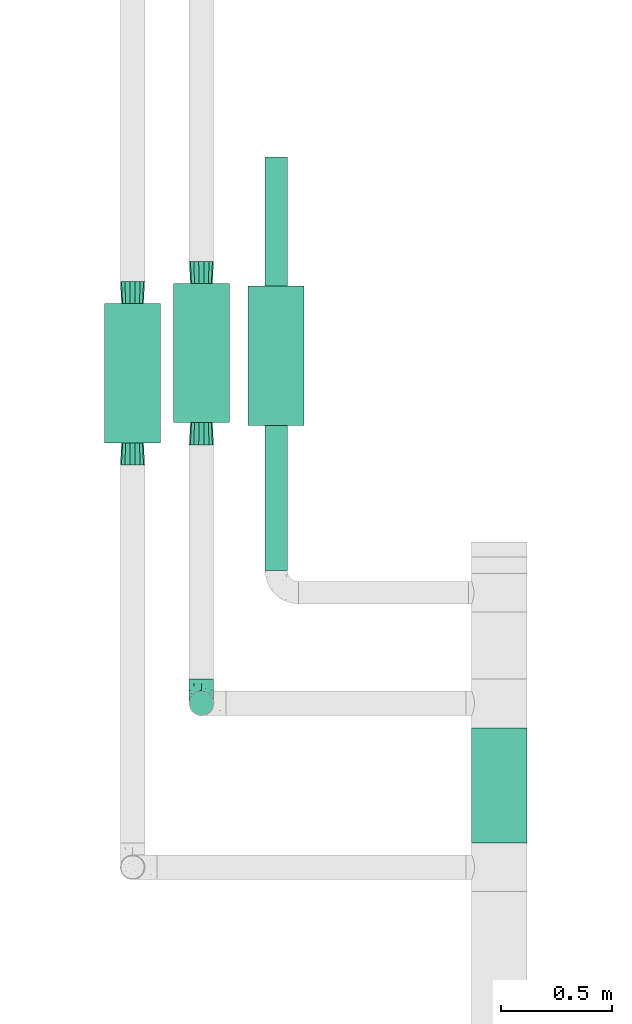
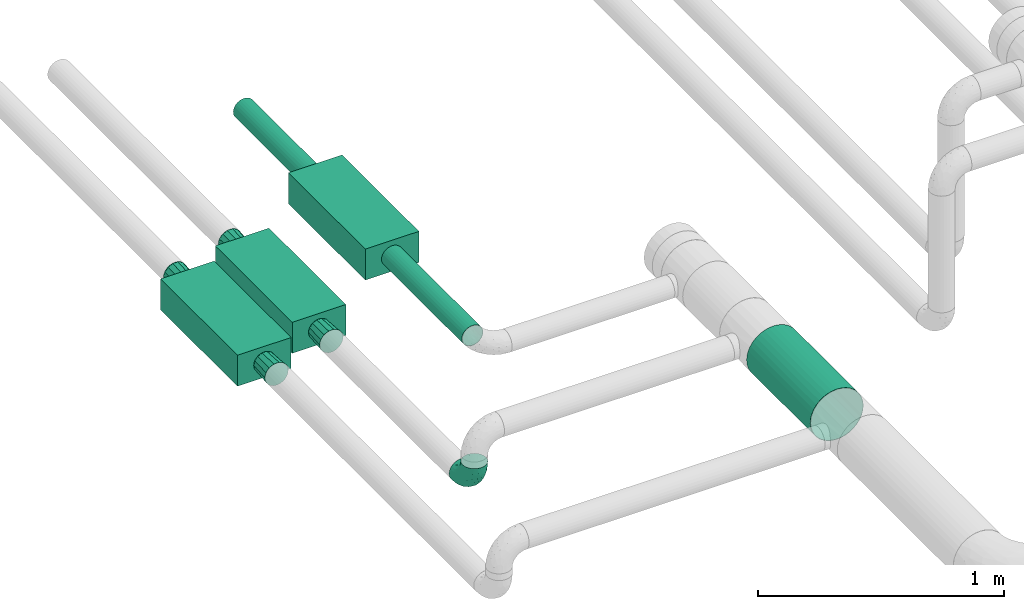
# One storey, part 38 of 91: 5 flow fittings, 3 flow segments, 3 flow treatment devices.
"""IFC2X3 building model written with IfcOpenShell, lengths in millimetres."""

from ifc_helpers import new_model, entity, si_unit, converted_unit, derived_unit, direction, frame, origin_with_axes, origin_2d_with_axis, place, context, subcontext, project, spatial, hollow_circle, extrude, open_shell, surface_model, source, transform, mapped, material, layer, layer_set, layer_usage, type_object, element, save


model = new_model("IFC2X3")

# Units and contexts
model_context = context("Model", 3, precision=1e-05, world=origin_with_axes(), true_north=direction((0.0, 1.0)))
body_context = subcontext(model_context, "Body", "Model", "MODEL_VIEW")
ifc_project = project(units=[si_unit("AREAUNIT", "SQUARE_METRE"), si_unit("VOLUMEUNIT", "CUBIC_METRE", prefix="DECI"), si_unit("TIMEUNIT", "SECOND"), si_unit("THERMODYNAMICTEMPERATUREUNIT", "DEGREE_CELSIUS"), si_unit("PRESSUREUNIT", "PASCAL"), si_unit("MASSUNIT", "GRAM", prefix="KILO"), si_unit("LENGTHUNIT", "METRE", prefix="MILLI"), si_unit("POWERUNIT", "WATT"), si_unit("ELECTRICCURRENTUNIT", "AMPERE"), si_unit("ELECTRICVOLTAGEUNIT", "VOLT"), derived_unit("VOLUMETRICFLOWRATEUNIT", [(si_unit("VOLUMEUNIT", "CUBIC_METRE", prefix="DECI"), 1), (si_unit("TIMEUNIT", "SECOND"), -1)]), derived_unit("LINEARVELOCITYUNIT", [(si_unit("LENGTHUNIT", "METRE"), 1), (si_unit("TIMEUNIT", "SECOND"), -1)]), derived_unit("MASSDENSITYUNIT", [(si_unit("MASSUNIT", "GRAM", prefix="KILO"), 1), (si_unit("VOLUMEUNIT", "CUBIC_METRE"), -1)]), converted_unit("PLANEANGLEUNIT", "DEGREE", entity("IfcRatioMeasure", 0.01745), si_unit("PLANEANGLEUNIT", "RADIAN"), dimensions=[0, 0, 0, 0, 0, 0, 0])], contexts=[model_context])

# Site, building, storey
site_placement = place(None, origin_with_axes())
site = spatial("IfcSite", under=ifc_project, at=site_placement, CompositionType="ELEMENT")
building_placement = place(site_placement, origin_with_axes())
building = spatial("IfcBuilding", under=site, at=building_placement, Name="mc-building", CompositionType="ELEMENT")
storey_placement = place(building_placement, frame((0.0, 0.0, 8700.0), z_axis=(0.0, 0.0, 1.0), x_axis=(1.0, 0.0, 0.0)))
storey = spatial("IfcBuildingStorey", under=building, at=storey_placement, CompositionType="ELEMENT", Elevation=8700.0)

# Flow segment
ifc_material = material(Name="FZ1")
ifc_layer = layer(ifc_material, 0.0)
ifc_layer_set = layer_set([ifc_layer], Name="FZ1")
ifc_layer_usage = layer_usage(ifc_layer_set, "AXIS1", "POSITIVE", 0.0)
duct_segment_type_1 = type_object("IfcDuctSegmentType", PredefinedType="RIGIDSEGMENT")
shared_shape_1 = source(origin_with_axes(), body_context, "Body", "SweptSolid", [
    extrude(hollow_circle(Radius=50.0, WallThickness=2.0, at=origin_2d_with_axis()), frame((0.0, 0.0, 0.0), z_axis=(1.0, 0.0, 0.0), x_axis=(0.0, 1.0, 0.0)), (0.0, 0.0, 1.0), 653.6),
])
flow_segment_1_placement = place(storey_placement, frame((5823.33283, 11426.86064, 668.0), z_axis=(0.0, 0.0, 1.0), x_axis=(0.0, -1.0, 0.0)))
element("IfcFlowSegment", 1, at=flow_segment_1_placement, inside=storey, type_object=duct_segment_type_1, material=ifc_layer_usage, context=body_context, shape_type="MappedRepresentation", body=[
    mapped(shared_shape_1, transform((0.0, 0.0, 0.0), scale=1.0)),
])

# Flow fitting
duct_fitting_type_1 = type_object("IfcDuctFittingType", Name="BU", PredefinedType="BEND")
shared_shape_2 = source(origin_with_axes(), body_context, "Body", "SurfaceModel", [
    surface_model("IfcShellBasedSurfaceModel", [(-110.0, 0.0, -55.0), (-110.0, -14.23505, -53.12592), (-110.0, 14.23505, -53.12592), (-110.0, 53.12592, 14.23505), (-110.0, 27.5, -47.63139), (-110.0, 38.89087, -38.89087), (-110.0, -55.0, 0.0), (-110.0, -53.12592, 14.23505), (-110.0, -38.89087, -38.89087), (-110.0, -27.5, -47.63139), (-110.0, -53.12592, -14.23505), (-110.0, -47.63139, -27.5), (-110.0, -14.23505, 53.12592), (-110.0, 14.23505, 53.12592), (-110.0, 27.5, 47.63139), (-110.0, -47.63139, 27.5), (-110.0, -38.89087, 38.89087), (-110.0, -27.5, 47.63139), (-110.0, 0.0, 55.0), (-110.0, 55.0, 0.0), (-110.0, 53.12592, -14.23505), (-110.0, 47.63139, -27.5), (-110.0, 47.63139, 27.5), (-110.0, 38.89087, 38.89087), (-14.23505, 110.0, -53.12592), (-55.0, 110.0, 0.0), (0.0, 110.0, -55.0), (-27.5, 110.0, -47.63139), (-38.89087, 110.0, -38.89087), (-47.63139, 110.0, -27.5), (38.89087, 110.0, -38.89087), (53.12592, 110.0, 14.23505), (27.5, 110.0, -47.63139), (14.23505, 110.0, -53.12592), (47.63139, 110.0, -27.5), (53.12592, 110.0, -14.23505), (55.0, 110.0, 0.0), (-53.12592, 110.0, -14.23505), (-53.12592, 110.0, 14.23505), (-47.63139, 110.0, 27.5), (-38.89087, 110.0, 38.89087), (-27.5, 110.0, 47.63139), (0.0, 110.0, 55.0), (-14.23505, 110.0, 53.12592), (38.89087, 110.0, 38.89087), (47.63139, 110.0, 27.5), (27.5, 110.0, 47.63139), (14.23505, 110.0, 53.12592), (-64.21732, 48.68956, 43.63444), (-76.6405, 38.18013, 45.55988), (-60.44912, 32.56953, 51.94617), (-76.00813, 5.38378, 55.0), (-90.15553, 11.94394, 54.09138), (-78.5998, 26.77405, 50.81338), (-70.18771, 18.55163, 54.03432), (-75.55424, 54.2118, 32.41257), (-93.27622, 45.77614, 33.48188), (-96.12334, 22.13664, 50.81337), (-21.00813, 45.34362, 55.0), (-18.36258, 70.48427, 54.04484), (-32.04182, 59.64019, 52.24446), (-63.88653, 74.77858, 17.99134), (-74.66383, 63.08407, 19.92123), (-63.60674, 66.07878, 29.97482), (-99.597, 52.72185, 18.52927), (-93.11138, 56.59448, 10.50359), (-98.21577, 57.34403, 0.0), (-53.42855, 92.60092, 21.04759), (-88.54852, 54.8376, 21.04759), (-11.86161, 90.23965, 54.10313), (-5.38378, 76.00813, 55.0), (-57.34403, 98.21577, 0.0), (-56.64619, 93.12774, 10.22088), (-45.34362, 21.00813, 55.0), (-44.60838, 44.60838, 52.13415), (-92.68484, 35.46673, 43.63443), (-22.25266, 95.40765, 50.81337), (-35.97783, 90.61597, 43.63443), (-43.70931, 69.58671, 44.47149), (-27.23711, 77.39884, 50.81337), (-57.2828, 79.3123, 24.9774), (-58.67786, 84.31125, 16.04456), (-82.93277, 60.36161, 12.91784), (-49.88337, 54.51816, 47.224), (-74.57753, 66.83759, 9.55742), (-45.35812, 94.97281, 33.48188), (-59.18663, 88.95241, 0.0), (-51.517, 78.6292, 33.48188), (-65.14788, 80.03077, 0.0), (-56.45322, 62.06476, 39.63545), (-88.95241, 59.18663, 0.0), (-71.10913, 71.10913, 0.0), (-80.03077, 65.14788, 0.0), (-94.9309, 45.36788, -33.48188), (-93.11358, 56.60141, -10.46614), (-99.64997, 52.79499, -18.30015), (-90.20425, 36.08686, -43.63443), (-79.99933, 46.56772, -37.92748), (-76.00813, 5.38378, -55.0), (-72.75364, 19.68651, -53.60527), (-45.34362, 21.00813, -55.0), (-21.91957, 65.12078, -53.85897), (-5.38378, 76.00813, -55.0), (-21.00813, 45.34362, -55.0), (-35.41876, 92.89265, -43.63443), (-91.10309, 11.02766, -54.21832), (-45.77614, 93.27622, -33.48188), (-90.50474, 23.21022, -50.81337), (-70.92854, 33.31794, -49.51754), (-78.52933, 63.35627, -11.73997), (-24.91508, 84.05606, -50.81337), (-88.78941, 54.74452, -21.04759), (-69.59921, 57.34866, -33.48187), (-73.36422, 62.46673, -22.94182), (-63.49062, 67.59111, -28.46929), (-56.59448, 93.11138, -10.50359), (-54.8376, 88.54852, -21.04759), (-54.10679, 75.85581, -32.31867), (-57.75956, 31.09612, -52.80882), (-52.72185, 99.597, -18.52927), (-12.62913, 89.46304, -53.99097), (-34.46825, 66.46123, -50.04329), (-43.9837, 43.9837, -52.42279), (-65.78527, 72.58348, -17.68796), (-70.34468, 43.65295, -44.21951), (-57.47001, 51.99467, -44.91465), (-60.72547, 82.29174, -12.88567), (-42.34915, 74.24548, -43.63444), (-57.25194, 63.5016, -38.08211), (-80.95344, 53.56991, -29.32027), (-52.32891, 4.55257, -54.0482), (32.52942, 47.13398, -30.48571), (14.88266, 20.92917, -33.7947), (14.95561, 36.05775, -42.26543), (30.24048, 70.09027, -41.7461), (19.3559, 65.35825, -48.00507), (-70.35075, -46.44478, -19.5952), (-47.13398, -32.52942, -30.48571), (-28.49299, -30.5778, -16.4009), (-4.55257, 52.32891, -54.0482), (-22.4954, 22.4954, -53.25347), (-75.47368, -11.22546, -52.60718), (-81.32209, -51.5606, -9.98467), (-80.81763, -41.84862, -32.14655), (-70.09027, -30.24048, -41.7461), (-36.05774, -14.95561, -42.26543), (-9.15831, -10.852, -27.8997), (-65.35825, -19.3559, -48.00507), (11.22546, 75.47368, -52.60718), (3.94376, 43.9333, -50.53315), (-13.39742, 13.39743, -48.13058), (-43.9333, -3.94376, -50.53315), (49.37776, 67.29486, 0.0), (41.8609, 47.82256, -9.92641), (50.20582, 74.51695, -9.9731), (18.93131, 11.7156, -17.56239), (-27.5, -32.89419, 0.0), (-1.23348, -12.25375, -12.18106), (41.84862, 80.81763, -32.14655), (35.70604, 41.31408, -20.38235), (46.44478, 70.35075, -19.5952), (32.89419, 27.5, 0.0), (6.67262, -6.67262, 0.0), (-67.29486, -49.37776, 0.0), (-50.36265, -42.95545, -9.51562), (-5.47251, 5.47251, -39.92906), (-70.35075, -46.44478, 19.5952), (-74.51695, -50.20582, 9.9731), (-41.31407, -35.70604, 20.38235), (-47.13398, -32.52942, 30.48571), (-80.81763, -41.84862, 32.14655), (-4.55257, 52.32891, 54.0482), (11.22546, 75.47368, 52.60718), (-43.9333, -3.94376, 50.53315), (-65.35825, -19.3559, 48.00507), (-36.05774, -14.95561, 42.26543), (-70.09027, -30.24048, 41.7461), (-11.7156, -18.93131, 17.56239), (30.5778, 28.49299, 16.4009), (12.25375, 1.23348, 12.18106), (51.5606, 81.32209, 9.98467), (42.95545, 50.36265, 9.51562), (-75.47368, -11.22546, 52.60718), (-52.32891, 4.55257, 54.0482), (3.94376, 43.9333, 50.53315), (-22.4954, 22.4954, 53.25347), (-13.39742, 13.39743, 48.13058), (10.852, 9.15831, 27.8997), (-20.92916, -14.88266, 33.79469), (-47.82256, -41.8609, 9.92641), (32.52942, 47.13398, 30.48571), (46.44478, 70.35075, 19.5952), (41.84862, 80.81763, 32.14655), (30.24048, 70.09027, 41.7461), (19.3559, 65.35825, 48.00507), (14.95561, 36.05775, 42.26543), (-5.47251, 5.47251, 39.92906)], [open_shell([[[0, 1, 2]], [[2, 3, 4]], [[4, 3, 5]], [[2, 6, 7]], [[8, 6, 9]], [[1, 9, 6]], [[10, 6, 11]], [[8, 11, 6]], [[6, 2, 1]], [[12, 13, 14]], [[15, 2, 7]], [[16, 17, 2]], [[2, 17, 12]], [[12, 18, 13]], [[19, 20, 3]], [[5, 3, 21]], [[20, 21, 3]], [[22, 3, 2]], [[23, 22, 2]], [[12, 14, 2]], [[2, 14, 23]], [[15, 16, 2]], [[24, 25, 26]], [[27, 25, 24]], [[25, 28, 29]], [[28, 25, 27]], [[30, 26, 31]], [[26, 30, 32]], [[32, 33, 26]], [[34, 31, 35]], [[31, 34, 30]], [[35, 31, 36]], [[29, 37, 25]], [[38, 39, 26]], [[39, 40, 26]], [[41, 42, 40]], [[42, 26, 40]], [[42, 41, 43]], [[26, 44, 45]], [[31, 26, 45]], [[26, 46, 44]], [[47, 46, 26]], [[42, 47, 26]], [[25, 38, 26]], [[48, 49, 50]], [[18, 51, 52]], [[53, 54, 50]], [[55, 56, 49]], [[56, 22, 23]], [[13, 57, 14]], [[58, 59, 60]], [[61, 62, 63]], [[3, 64, 65]], [[53, 52, 54]], [[3, 65, 66]], [[67, 39, 38]], [[56, 68, 64]], [[65, 64, 68]], [[69, 59, 70]], [[38, 71, 72]], [[73, 58, 74]], [[75, 49, 56]], [[76, 69, 43]], [[53, 57, 52]], [[77, 78, 79]], [[41, 76, 43]], [[43, 69, 42]], [[55, 68, 56]], [[23, 14, 75]], [[76, 77, 79]], [[80, 67, 81]], [[62, 82, 68]], [[60, 78, 83]], [[62, 84, 82]], [[85, 77, 40]], [[81, 67, 72]], [[86, 72, 71]], [[87, 85, 67]], [[61, 81, 88]], [[77, 41, 40]], [[78, 77, 87]], [[23, 75, 56]], [[83, 89, 48]], [[85, 40, 39]], [[62, 68, 55]], [[89, 87, 63]], [[83, 48, 50]], [[57, 75, 14]], [[49, 75, 53]], [[67, 85, 39]], [[87, 77, 85]], [[63, 62, 55]], [[89, 55, 48]], [[80, 63, 87]], [[66, 65, 90]], [[66, 19, 3]], [[84, 91, 92]], [[92, 90, 82]], [[65, 82, 90]], [[61, 84, 62]], [[92, 82, 84]], [[68, 82, 65]], [[3, 22, 64]], [[56, 64, 22]], [[38, 25, 71]], [[81, 72, 86]], [[38, 72, 67]], [[91, 61, 88]], [[80, 81, 61]], [[63, 80, 61]], [[67, 80, 87]], [[77, 76, 41]], [[79, 59, 69]], [[79, 69, 76]], [[42, 69, 70]], [[60, 59, 79]], [[58, 70, 59]], [[78, 60, 79]], [[58, 60, 74]], [[52, 57, 13]], [[75, 57, 53]], [[18, 52, 13]], [[52, 51, 54]], [[51, 73, 54]], [[50, 73, 74]], [[73, 50, 54]], [[50, 74, 83]], [[60, 83, 74]], [[89, 83, 78]], [[87, 89, 78]], [[55, 89, 63]], [[50, 49, 53]], [[55, 49, 48]], [[81, 86, 88]], [[91, 84, 61]], [[5, 21, 93]], [[90, 94, 66]], [[20, 94, 95]], [[96, 93, 97]], [[98, 99, 100]], [[96, 4, 5]], [[101, 102, 103]], [[28, 27, 104]], [[2, 105, 0]], [[104, 106, 28]], [[99, 105, 107]], [[108, 107, 96]], [[90, 109, 94]], [[107, 2, 4]], [[20, 66, 94]], [[27, 24, 110]], [[109, 111, 94]], [[112, 113, 114]], [[37, 115, 71]], [[116, 106, 117]], [[99, 118, 100]], [[116, 115, 119]], [[37, 119, 115]], [[24, 120, 110]], [[121, 110, 101]], [[119, 106, 116]], [[101, 110, 120]], [[122, 103, 100]], [[117, 123, 116]], [[124, 125, 108]], [[115, 116, 126]], [[106, 29, 28]], [[26, 102, 120]], [[127, 104, 110]], [[97, 124, 96]], [[125, 122, 118]], [[128, 127, 125]], [[96, 5, 93]], [[115, 126, 86]], [[117, 106, 127]], [[111, 113, 129]], [[95, 93, 21]], [[97, 129, 112]], [[110, 104, 27]], [[106, 104, 127]], [[96, 107, 4]], [[99, 107, 108]], [[99, 108, 118]], [[105, 99, 98]], [[112, 114, 128]], [[121, 125, 127]], [[20, 19, 66]], [[109, 90, 92]], [[94, 111, 95]], [[91, 123, 109]], [[129, 113, 112]], [[93, 95, 111]], [[21, 20, 95]], [[71, 115, 86]], [[71, 25, 37]], [[123, 91, 88]], [[126, 116, 123]], [[123, 88, 126]], [[86, 126, 88]], [[37, 29, 119]], [[106, 119, 29]], [[129, 93, 111]], [[124, 112, 125]], [[0, 105, 98]], [[107, 105, 2]], [[125, 118, 108]], [[100, 118, 122]], [[93, 129, 97]], [[113, 111, 109]], [[109, 123, 113]], [[114, 123, 117]], [[123, 114, 113]], [[128, 114, 117]], [[127, 128, 117]], [[112, 128, 125]], [[103, 122, 101]], [[110, 121, 127]], [[101, 122, 121]], [[125, 121, 122]], [[26, 120, 24]], [[101, 120, 102]], [[96, 124, 108]], [[92, 91, 109]], [[112, 124, 97]], [[100, 130, 98]], [[131, 132, 133]], [[32, 134, 135]], [[136, 137, 138]], [[139, 140, 103]], [[98, 141, 0]], [[142, 10, 136]], [[143, 144, 137]], [[6, 10, 142]], [[137, 145, 146]], [[144, 147, 145]], [[143, 136, 11]], [[11, 136, 10]], [[8, 143, 11]], [[148, 149, 139]], [[8, 9, 144]], [[9, 1, 147]], [[130, 141, 98]], [[103, 140, 100]], [[148, 135, 149]], [[150, 151, 140]], [[152, 153, 154]], [[130, 140, 151]], [[148, 26, 33]], [[147, 1, 141]], [[155, 146, 132]], [[156, 138, 157]], [[134, 30, 158]], [[150, 140, 149]], [[158, 30, 34]], [[30, 134, 32]], [[153, 159, 160]], [[131, 160, 159]], [[144, 145, 137]], [[36, 152, 154]], [[146, 138, 137]], [[155, 161, 162]], [[158, 160, 131]], [[133, 149, 135]], [[156, 163, 164]], [[163, 142, 164]], [[139, 103, 102]], [[153, 152, 161]], [[34, 35, 160]], [[162, 157, 155]], [[132, 165, 133]], [[157, 146, 155]], [[140, 130, 100]], [[141, 130, 151]], [[141, 151, 147]], [[141, 1, 0]], [[102, 26, 148]], [[140, 139, 149]], [[102, 148, 139]], [[135, 33, 32]], [[151, 150, 145]], [[9, 147, 144]], [[151, 145, 147]], [[145, 165, 146]], [[135, 148, 33]], [[133, 135, 134]], [[131, 133, 134]], [[133, 165, 150]], [[133, 150, 149]], [[145, 150, 165]], [[132, 131, 159]], [[146, 165, 132]], [[160, 158, 34]], [[134, 158, 131]], [[144, 143, 8]], [[136, 143, 137]], [[155, 153, 161]], [[154, 153, 160]], [[153, 155, 159]], [[132, 159, 155]], [[160, 35, 154]], [[36, 154, 35]], [[164, 136, 138]], [[6, 142, 163]], [[136, 164, 142]], [[156, 164, 138]], [[156, 157, 162]], [[146, 157, 138]], [[15, 7, 166]], [[6, 163, 167]], [[168, 169, 166]], [[166, 169, 170]], [[171, 172, 70]], [[173, 174, 175]], [[17, 176, 174]], [[177, 156, 162]], [[176, 16, 170]], [[170, 16, 15]], [[161, 178, 179]], [[152, 180, 181]], [[182, 173, 183]], [[18, 12, 182]], [[184, 185, 186]], [[183, 185, 73]], [[183, 73, 51]], [[177, 187, 188]], [[189, 168, 166]], [[187, 178, 190]], [[16, 176, 17]], [[161, 152, 181]], [[45, 191, 31]], [[45, 44, 192]], [[192, 191, 45]], [[180, 36, 31]], [[193, 194, 195]], [[46, 47, 194]], [[193, 195, 190]], [[193, 44, 46]], [[172, 42, 70]], [[185, 58, 73]], [[189, 163, 156]], [[163, 189, 167]], [[70, 58, 171]], [[184, 171, 185]], [[169, 188, 175]], [[180, 31, 191]], [[192, 193, 190]], [[191, 190, 178]], [[182, 174, 173]], [[194, 47, 172]], [[190, 195, 187]], [[186, 185, 173]], [[162, 179, 177]], [[188, 196, 175]], [[179, 187, 177]], [[185, 171, 58]], [[172, 171, 184]], [[172, 184, 194]], [[172, 47, 42]], [[51, 18, 182]], [[185, 183, 173]], [[51, 182, 183]], [[174, 12, 17]], [[184, 186, 195]], [[46, 194, 193]], [[184, 195, 194]], [[195, 196, 187]], [[174, 182, 12]], [[175, 174, 176]], [[169, 175, 176]], [[175, 196, 186]], [[175, 186, 173]], [[195, 186, 196]], [[188, 169, 168]], [[187, 196, 188]], [[166, 170, 15]], [[176, 170, 169]], [[193, 192, 44]], [[191, 192, 190]], [[177, 189, 156]], [[167, 189, 166]], [[189, 177, 168]], [[188, 168, 177]], [[166, 7, 167]], [[6, 167, 7]], [[181, 191, 178]], [[36, 180, 152]], [[191, 181, 180]], [[161, 181, 178]], [[161, 179, 162]], [[187, 179, 178]]])]),
])
flow_fitting_placement = place(storey_placement, frame((5487.14677, 10175.43966, 415.0), z_axis=(-1.0, 0.0, 0.0), x_axis=(0.0, -1.0, 0.0)))
element("IfcFlowFitting", 2, at=flow_fitting_placement, inside=storey, type_object=duct_fitting_type_1, Name="BU", context=body_context, shape_type="MappedRepresentation", body=[
    mapped(shared_shape_2, transform((0.0, 0.0, 0.0), scale=1.0)),
])

# Flow segment
duct_segment_type_2 = type_object("IfcDuctSegmentType", Name="Safe", PredefinedType="RIGIDSEGMENT")
shared_shape_3 = source(origin_with_axes(), body_context, "Body", "SweptSolid", [
    extrude(hollow_circle(Radius=125.0, WallThickness=2.0, at=origin_2d_with_axis()), frame((0.0, 0.0, 0.0), z_axis=(1.0, 0.0, 0.0), x_axis=(0.0, 1.0, 0.0)), (0.0, 0.0, 1.0), 517.5),
])
flow_segment_2_placement = place(storey_placement, frame((6828.023, 9547.92738, 668.0), z_axis=(0.0, 0.0, 1.0), x_axis=(0.0, 1.0, 0.0)))
element("IfcFlowSegment", 3, at=flow_segment_2_placement, inside=storey, type_object=duct_segment_type_2, material=ifc_layer_usage, Name="Safe", context=body_context, shape_type="MappedRepresentation", body=[
    mapped(shared_shape_3, transform((0.0, 0.0, 0.0), scale=1.0)),
])

# Flow treatment devices
duct_silencer_type = type_object("IfcDuctSilencerType", PredefinedType="ROUND")
shared_shape_4 = source(origin_with_axes(), body_context, "Body", "SurfaceModel", [
    surface_model("IfcShellBasedSurfaceModel", [(313.0, 126.0, 77.0), (313.0, -126.0, 77.0), (313.0, -126.0, -77.0), (313.0, 126.0, -77.0), (-313.0, 126.0, -77.0), (-313.0, -126.0, -77.0), (-313.0, -126.0, 77.0), (-313.0, 126.0, 77.0)], [open_shell([[[0, 1, 2]], [[2, 3, 0]], [[4, 5, 6]], [[6, 7, 4]], [[2, 1, 6]], [[6, 5, 2]], [[3, 2, 4]], [[5, 4, 2]], [[0, 3, 4]], [[4, 7, 0]], [[1, 0, 6]], [[7, 6, 0]]])]),
])
for number, where, z_axis, x_axis in (
    (4, (5177.14677, 11660.78475, 415.0), (0.0, 0.0, 1.0), (0.0, -1.0, 0.0)),
    (5, (5487.14677, 11751.9838, 415.0), (0.0, 0.0, 1.0), (0.0, -1.0, 0.0)),
    (6, (5823.33283, 11739.86064, 668.0), (0.0, 0.0, 1.0), (0.0, -1.0, 0.0)),
):
    element("IfcFlowTreatmentDevice", number, at=place(storey_placement, frame(where, z_axis=z_axis, x_axis=x_axis)), inside=storey, type_object=duct_silencer_type, context=body_context, shape_type="MappedRepresentation", body=[
        mapped(shared_shape_4, transform((0.0, 0.0, 0.0), scale=1.0)),
    ])

# Flow fittings
duct_fitting_type_2 = type_object("IfcDuctFittingType", PredefinedType="TRANSITION")
shared_shape_5 = source(origin_with_axes(), body_context, "Body", "SurfaceModel", [
    surface_model("IfcShellBasedSurfaceModel", [(0.0, 12.94095, 48.29629), (0.0, -35.35534, 35.35534), (0.0, 0.0, 50.0), (0.0, 35.35534, 35.35534), (0.0, 25.0, 43.30127), (0.0, 43.30127, 25.0), (0.0, 48.29629, 12.94095), (0.0, -12.94095, 48.29629), (0.0, -25.0, 43.30127), (0.0, -48.29629, 12.94095), (0.0, -43.30127, 25.0), (0.0, -25.0, -43.30127), (0.0, -48.29629, -12.94095), (0.0, -50.0, 0.0), (0.0, 48.29629, -12.94095), (0.0, 12.94095, -48.29629), (0.0, 43.30127, -25.0), (0.0, 35.35534, -35.35534), (0.0, 25.0, -43.30127), (0.0, -35.35534, -35.35534), (0.0, -43.30127, -25.0), (0.0, -12.94095, -48.29629), (0.0, 0.0, -50.0), (0.0, 50.0, 0.0), (100.0, -55.0, 0.0), (100.0, -12.23865, 53.62104), (100.0, -34.29194, 43.00073), (100.0, 49.55329, -23.86361), (100.0, 12.23865, 53.62104), (100.0, 34.29194, 43.00073), (100.0, 55.0, 0.0), (100.0, 49.55329, 23.86361), (100.0, -49.55329, 23.86361), (100.0, 12.23865, -53.62104), (100.0, -49.55329, -23.86361), (100.0, -34.29194, -43.00073), (100.0, 34.29194, -43.00073), (100.0, -12.23865, -53.62104), (0.0, 11.12605, 48.7464), (0.0, -11.12605, 48.7464), (0.0, 31.17449, 39.09157), (0.0, -45.04844, -21.69419), (0.0, -45.04844, 21.69419), (0.0, -31.17449, 39.09157), (0.0, 45.04844, 21.69419), (0.0, 45.04844, -21.69419), (0.0, 31.17449, -39.09157), (0.0, -31.17449, -39.09157), (0.0, -11.12605, -48.7464), (0.0, 11.12605, -48.7464), (0.0, -47.52422, -10.84709), (100.0, -41.92261, -33.43217), (0.0, -38.11147, -30.39288), (100.0, 41.92261, -33.43217), (0.0, 38.11147, -30.39288), (0.0, -21.15027, -43.91899), (100.0, -23.2653, -48.31088), (100.0, -52.32388, -11.72483), (100.0, 0.0, -53.62104), (0.0, 0.0, -48.7464), (100.0, 23.2653, -48.31088), (0.0, 21.15027, -43.91899), (100.0, 52.32388, -11.72483), (0.0, 47.52422, -10.84709), (0.0, 47.52422, 10.84709), (100.0, 41.92261, 33.43217), (0.0, 38.11147, 30.39288), (100.0, -41.92261, 33.43217), (0.0, -38.11147, 30.39288), (0.0, 21.15027, 43.91899), (100.0, 23.2653, 48.31088), (100.0, 52.32388, 11.72483), (100.0, 0.0, 53.62104), (0.0, 0.0, 48.7464), (100.0, -23.2653, 48.31088), (0.0, -21.15027, 43.91899), (100.0, -52.32388, 11.72483), (0.0, -47.52422, 10.84709), (100.0, 27.5, -47.63139), (100.0, 0.0, -55.0), (100.0, 14.23505, -53.12592), (100.0, 38.89087, -38.89087), (100.0, -27.5, -47.63139), (100.0, 47.63139, -27.5), (100.0, 53.12592, -14.23505), (100.0, -14.23505, -53.12592), (100.0, -47.63139, -27.5), (100.0, -38.89087, -38.89087), (100.0, -53.12592, -14.23505), (100.0, 53.12592, 14.23505), (100.0, 47.63139, 27.5), (100.0, 27.5, 47.63139), (100.0, 38.89087, 38.89087), (100.0, 14.23505, 53.12592), (100.0, 0.0, 55.0), (100.0, -47.63139, 27.5), (100.0, -53.12592, 14.23505), (100.0, -27.5, 47.63139), (100.0, -38.89087, 38.89087), (100.0, -14.23505, 53.12592), (98.0, 0.0, 55.0), (98.0, 14.23505, 53.12592), (98.0, 27.5, 47.63139), (98.0, 38.89087, 38.89087), (98.0, 47.63139, 27.5), (98.0, -47.63139, 27.5), (98.0, 53.12592, -14.23505), (98.0, -27.5, 47.63139), (98.0, -14.23505, 53.12592), (98.0, -38.89087, 38.89087), (98.0, -55.0, 0.0), (98.0, -53.12592, 14.23505), (98.0, 53.12592, 14.23505), (98.0, 47.63139, -27.5), (98.0, -27.5, -47.63139), (98.0, 0.0, -55.0), (98.0, 38.89087, -38.89087), (98.0, 27.5, -47.63139), (98.0, 14.23505, -53.12592), (98.0, -47.63139, -27.5), (98.0, -38.89087, -38.89087), (98.0, -53.12592, -14.23505), (98.0, -14.23505, -53.12592), (98.0, 55.0, 0.0), (2.0, 12.94095, -48.29629), (2.0, 25.0, -43.30127), (2.0, 35.35534, -35.35534), (2.0, 43.30127, -25.0), (2.0, 48.29629, -12.94095), (2.0, 0.0, -50.0), (2.0, 50.0, 0.0), (2.0, -25.0, -43.30127), (2.0, -12.94095, -48.29629), (2.0, -35.35534, -35.35534), (2.0, -48.29629, -12.94095), (2.0, -43.30127, -25.0), (2.0, -48.29629, 12.94095), (2.0, 48.29629, 12.94095), (2.0, 43.30127, 25.0), (2.0, 35.35534, 35.35534), (2.0, -35.35534, 35.35534), (2.0, 12.94095, 48.29629), (2.0, 25.0, 43.30127), (2.0, 0.0, 50.0), (2.0, -43.30127, 25.0), (2.0, -50.0, 0.0), (2.0, -12.94095, 48.29629), (2.0, -25.0, 43.30127)], [open_shell([[[0, 1, 2]], [[3, 0, 4]], [[3, 5, 6]], [[0, 3, 1]], [[6, 1, 3]], [[7, 1, 8]], [[7, 2, 1]], [[1, 9, 10]], [[9, 1, 11]], [[12, 13, 9]], [[11, 1, 6]], [[6, 14, 11]], [[15, 14, 16]], [[17, 18, 15]], [[17, 15, 16]], [[11, 14, 15]], [[12, 19, 20]], [[19, 12, 11]], [[15, 21, 11]], [[12, 9, 11]], [[22, 21, 15]], [[14, 6, 23]], [[24, 25, 26]], [[25, 27, 28]], [[29, 28, 27]], [[27, 30, 31]], [[31, 29, 27]], [[24, 26, 32]], [[33, 24, 34]], [[33, 34, 35]], [[36, 27, 33]], [[33, 27, 24]], [[35, 37, 33]], [[24, 27, 25]], [[38, 23, 39]], [[40, 23, 38]], [[41, 42, 43]], [[41, 13, 42]], [[23, 43, 39]], [[40, 44, 23]], [[41, 23, 45]], [[41, 45, 46]], [[47, 41, 48]], [[49, 48, 41]], [[41, 46, 49]], [[23, 41, 43]], [[34, 50, 41]], [[47, 51, 52]], [[45, 27, 53]], [[36, 54, 53]], [[55, 48, 56]], [[34, 57, 50]], [[57, 13, 50]], [[13, 57, 24]], [[55, 35, 47]], [[35, 51, 47]], [[51, 41, 52]], [[58, 59, 49]], [[60, 61, 46]], [[37, 59, 58]], [[62, 63, 23]], [[35, 55, 56]], [[23, 30, 62]], [[53, 54, 45]], [[48, 37, 56]], [[33, 49, 61]], [[49, 33, 58]], [[54, 36, 46]], [[63, 27, 45]], [[34, 41, 51]], [[33, 61, 60]], [[48, 59, 37]], [[27, 63, 62]], [[46, 36, 60]], [[31, 64, 44]], [[40, 65, 66]], [[42, 32, 67]], [[26, 68, 67]], [[69, 38, 70]], [[31, 71, 64]], [[71, 23, 64]], [[23, 71, 30]], [[69, 29, 40]], [[29, 65, 40]], [[65, 44, 66]], [[72, 73, 39]], [[74, 75, 43]], [[28, 73, 72]], [[76, 77, 13]], [[29, 69, 70]], [[13, 24, 76]], [[67, 68, 42]], [[38, 28, 70]], [[25, 39, 75]], [[39, 25, 72]], [[68, 26, 43]], [[77, 32, 42]], [[31, 44, 65]], [[25, 75, 74]], [[38, 73, 28]], [[32, 77, 76]], [[43, 26, 74]], [[78, 79, 80]], [[81, 82, 78]], [[82, 83, 84]], [[81, 83, 82]], [[30, 82, 84]], [[79, 82, 85]], [[79, 78, 82]], [[82, 86, 87]], [[82, 30, 86]], [[24, 88, 86]], [[86, 30, 89]], [[90, 24, 89]], [[91, 90, 92]], [[91, 93, 94]], [[90, 91, 24]], [[94, 95, 91]], [[24, 95, 96]], [[24, 91, 95]], [[94, 97, 98]], [[98, 95, 94]], [[97, 94, 99]], [[89, 24, 86]], [[100, 101, 102]], [[100, 102, 103]], [[100, 104, 105]], [[104, 100, 103]], [[106, 105, 104]], [[100, 107, 108]], [[100, 109, 107]], [[105, 110, 111]], [[109, 100, 105]], [[105, 106, 110]], [[106, 104, 112]], [[106, 113, 110]], [[113, 114, 110]], [[115, 116, 117]], [[113, 116, 115]], [[117, 118, 115]], [[119, 114, 120]], [[121, 110, 119]], [[114, 115, 122]], [[119, 110, 114]], [[115, 114, 113]], [[123, 106, 112]], [[121, 88, 110]], [[119, 86, 121]], [[82, 120, 114]], [[119, 120, 87]], [[85, 114, 122]], [[121, 86, 88]], [[88, 24, 110]], [[85, 82, 114]], [[87, 120, 82]], [[87, 86, 119]], [[79, 85, 122]], [[122, 115, 79]], [[118, 80, 115]], [[117, 78, 118]], [[83, 116, 113]], [[117, 116, 81]], [[84, 113, 106]], [[117, 81, 78]], [[78, 80, 118]], [[30, 84, 106]], [[83, 113, 84]], [[83, 81, 116]], [[123, 30, 106]], [[115, 80, 79]], [[112, 89, 123]], [[104, 90, 112]], [[91, 103, 102]], [[104, 103, 92]], [[93, 102, 101]], [[112, 90, 89]], [[89, 30, 123]], [[93, 91, 102]], [[92, 103, 91]], [[92, 90, 104]], [[94, 93, 101]], [[101, 100, 94]], [[108, 99, 100]], [[107, 97, 108]], [[95, 109, 105]], [[107, 109, 98]], [[96, 105, 111]], [[107, 98, 97]], [[97, 99, 108]], [[24, 96, 111]], [[95, 105, 96]], [[95, 98, 109]], [[110, 24, 111]], [[100, 99, 94]], [[124, 125, 126]], [[124, 126, 127]], [[124, 128, 129]], [[128, 124, 127]], [[129, 128, 130]], [[129, 131, 132]], [[129, 130, 131]], [[133, 134, 135]], [[134, 133, 131]], [[131, 136, 134]], [[131, 130, 137]], [[137, 138, 139]], [[140, 137, 139]], [[140, 139, 141]], [[141, 139, 142]], [[140, 141, 143]], [[136, 140, 144]], [[145, 134, 136]], [[140, 146, 147]], [[131, 140, 136]], [[143, 146, 140]], [[131, 137, 140]], [[12, 134, 13]], [[20, 135, 12]], [[131, 19, 11]], [[20, 19, 133]], [[132, 11, 21]], [[12, 135, 134]], [[134, 145, 13]], [[132, 131, 11]], [[133, 19, 131]], [[133, 135, 20]], [[129, 132, 21]], [[21, 22, 129]], [[15, 124, 22]], [[18, 125, 15]], [[127, 17, 16]], [[18, 17, 126]], [[128, 16, 14]], [[18, 126, 125]], [[125, 124, 15]], [[130, 128, 14]], [[127, 16, 128]], [[127, 126, 17]], [[23, 130, 14]], [[22, 124, 129]], [[6, 137, 23]], [[5, 138, 6]], [[142, 3, 4]], [[5, 3, 139]], [[141, 4, 0]], [[6, 138, 137]], [[137, 130, 23]], [[141, 142, 4]], [[139, 3, 142]], [[139, 138, 5]], [[143, 141, 0]], [[0, 2, 143]], [[7, 146, 2]], [[8, 147, 7]], [[144, 1, 10]], [[8, 1, 140]], [[136, 10, 9]], [[8, 140, 147]], [[147, 146, 7]], [[145, 136, 9]], [[144, 10, 136]], [[144, 140, 1]], [[13, 145, 9]], [[2, 146, 143]]])]),
])
for number, where, z_axis, x_axis in (
    (7, (5177.14677, 11973.78475, 415.0), (0.0, 0.0, 1.0), (0.0, 1.0, 0.0)),
    (8, (5177.14677, 11347.78475, 415.0), (0.0, 0.0, 1.0), (0.0, -1.0, 0.0)),
    (9, (5487.14677, 12064.9838, 415.0), (0.0, 0.0, 1.0), (0.0, 1.0, 0.0)),
    (10, (5487.14677, 11438.9838, 415.0), (0.0, 0.0, 1.0), (0.0, -1.0, 0.0)),
):
    element("IfcFlowFitting", number, at=place(storey_placement, frame(where, z_axis=z_axis, x_axis=x_axis)), inside=storey, type_object=duct_fitting_type_2, context=body_context, shape_type="MappedRepresentation", body=[
        mapped(shared_shape_5, transform((0.0, 0.0, 0.0), scale=1.0)),
    ])

# Flow segment
shared_shape_6 = source(origin_with_axes(), body_context, "Body", "SweptSolid", [
    extrude(hollow_circle(Radius=50.0, WallThickness=2.0, at=origin_2d_with_axis()), frame((0.0, 0.0, 0.0), z_axis=(1.0, 0.0, 0.0), x_axis=(0.0, 1.0, 0.0)), (0.0, 0.0, 1.0), 580.6),
])
flow_segment_3_placement = place(storey_placement, frame((5823.33283, 12052.86064, 668.0), z_axis=(0.0, 0.0, 1.0), x_axis=(0.0, 1.0, 0.0)))
element("IfcFlowSegment", 11, at=flow_segment_3_placement, inside=storey, type_object=duct_segment_type_1, material=ifc_layer_usage, context=body_context, shape_type="MappedRepresentation", body=[
    mapped(shared_shape_6, transform((0.0, 0.0, 0.0), scale=1.0)),
])

save(model, "model.ifc")
